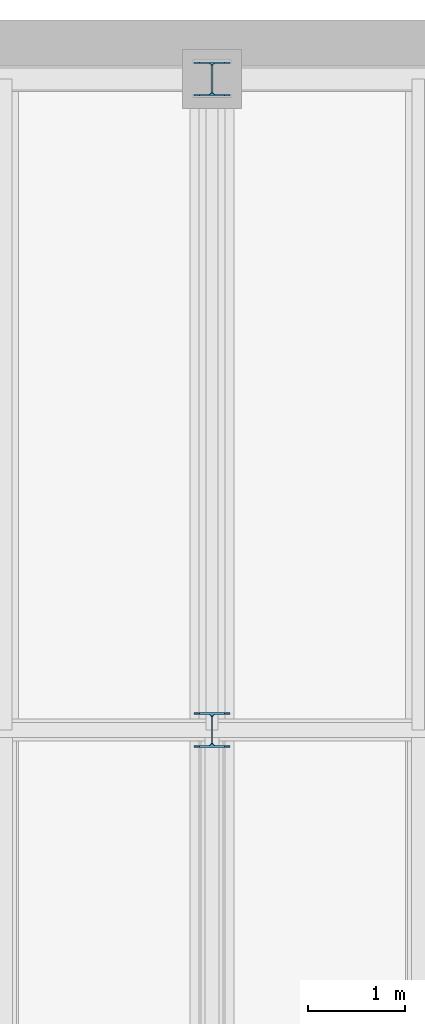
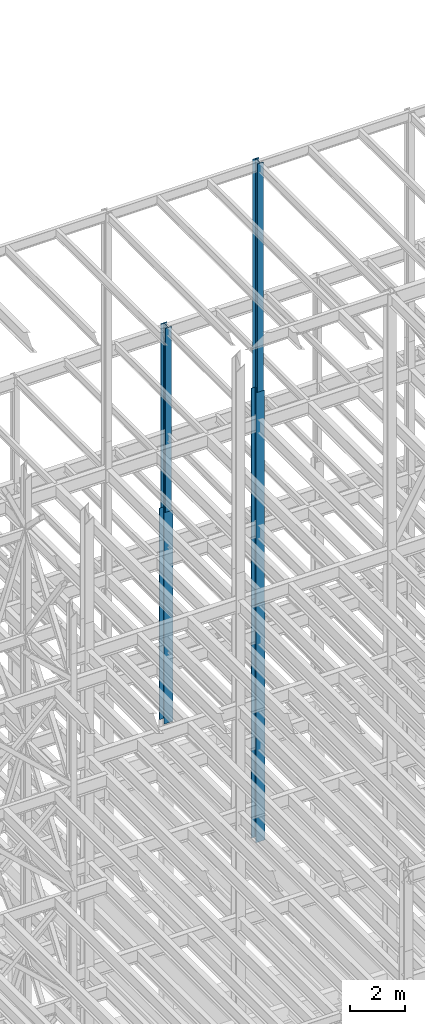
# One storey, part 60 of 150: 5 columns.
"""IFC2X3 building model written with IfcOpenShell, lengths in millimetres."""

from ifc_helpers import new_model, si_unit, frame, origin_with_axes, origin_2d_with_axis, place, context, subcontext, project, spatial, i_section, extrude, material, type_object, element, save


model = new_model("IFC2X3")

# Units and contexts
model_context = context("Model", 3, precision=1e-05, world=origin_with_axes())
body_context = subcontext(model_context, "Body", "Model", "MODEL_VIEW")
ifc_project = project(units=[si_unit("LENGTHUNIT", "METRE", prefix="MILLI"), si_unit("AREAUNIT", "SQUARE_METRE"), si_unit("VOLUMEUNIT", "CUBIC_METRE"), si_unit("MASSUNIT", "GRAM", prefix="KILO"), si_unit("TIMEUNIT", "SECOND"), si_unit("PLANEANGLEUNIT", "RADIAN"), si_unit("SOLIDANGLEUNIT", "STERADIAN"), si_unit("THERMODYNAMICTEMPERATUREUNIT", "DEGREE_CELSIUS"), si_unit("LUMINOUSINTENSITYUNIT", "LUMEN")], contexts=[model_context])

# Site, building, storey
site_placement = place(None, origin_with_axes())
site = spatial("IfcSite", under=ifc_project, at=site_placement, CompositionType="ELEMENT")
building_placement = place(site_placement, origin_with_axes())
building = spatial("IfcBuilding", under=site, at=building_placement, Name="Undefined", CompositionType="ELEMENT")
storey_placement = place(building_placement, origin_with_axes())
storey = spatial("IfcBuildingStorey", under=building, at=storey_placement, Name="Undefined", CompositionType="ELEMENT", Elevation=0.0)

# Columns
ifc_material = material(Name="STEEL/A992")
column_type_1 = type_object("IfcColumnType", Name="W14X61", PredefinedType="NOTDEFINED")
column_1_placement = place(storey_placement, frame((24587.2, 38862.0, 46253.4), z_axis=(0.0, 0.0, 1.0), x_axis=(1.0, 0.0, 0.0)))
element("IfcColumn", 1, at=column_1_placement, inside=storey, type_object=column_type_1, material=ifc_material, Name="COLUMN", ObjectType="W14X61", context=body_context, shape_type="SweptSolid", body=[
    extrude(i_section(OverallWidth=254.0, OverallDepth=352.425, WebThickness=9.5249, FlangeThickness=16.383, FilletRadius=21.717, at=origin_2d_with_axis()), frame((0.0, 0.0, 8229.60000000002), z_axis=(0.0, 0.0, -1.0), x_axis=(-1.0, 0.0, 0.0)), (0.0, 0.0, 1.0), 8229.60000000002),
])
column_type_2 = type_object("IfcColumnType", Name="W14X90", PredefinedType="NOTDEFINED")
column_2_placement = place(storey_placement, frame((24587.2, 38862.0, 36804.6012877801), z_axis=(0.0, 0.0, 1.0), x_axis=(1.0, 0.0, 0.0)))
element("IfcColumn", 2, at=column_2_placement, inside=storey, type_object=column_type_2, material=ifc_material, Name="COLUMN", ObjectType="W14X90", context=body_context, shape_type="SweptSolid", body=[
    extrude(i_section(OverallWidth=368.3, OverallDepth=355.6, WebThickness=11.1125, FlangeThickness=18.034, FilletRadius=32.7659, at=origin_2d_with_axis()), frame((0.0, 0.0, 9448.79776734), z_axis=(0.0, 0.0, -1.0), x_axis=(-1.0, 0.0, 0.0)), (0.0, 0.0, 1.0), 9448.79776734),
])
column_3_placement = place(storey_placement, frame((24587.2, 32131.0, 46253.4009448801), z_axis=(0.0, 0.0, 1.0), x_axis=(1.0, 0.0, 0.0)))
element("IfcColumn", 3, at=column_3_placement, inside=storey, type_object=column_type_2, material=ifc_material, Name="COLUMN", ObjectType="W14X90", context=body_context, shape_type="SweptSolid", body=[
    extrude(i_section(OverallWidth=368.3, OverallDepth=355.6, WebThickness=11.1125, FlangeThickness=18.034, FilletRadius=32.7659, at=origin_2d_with_axis()), frame((0.0, 0.0, 9448.79905511992), z_axis=(0.0, 0.0, -1.0), x_axis=(-1.0, 0.0, 0.0)), (0.0, 0.0, 1.0), 9448.7990551199),
])
column_type_3 = type_object("IfcColumnType", Name="W14X99", PredefinedType="NOTDEFINED")
column_4_placement = place(storey_placement, frame((24587.2, 32131.0, 35585.4), z_axis=(0.0, 0.0, 1.0), x_axis=(1.0, 0.0, 0.0)))
element("IfcColumn", 4, at=column_4_placement, inside=storey, type_object=column_type_3, material=ifc_material, Name="COLUMN", ObjectType="W14X99", context=body_context, shape_type="SweptSolid", body=[
    extrude(i_section(OverallWidth=370.84, OverallDepth=358.775, WebThickness=12.6999, FlangeThickness=19.812, FilletRadius=32.5755, at=origin_2d_with_axis()), frame((0.0, 0.0, 10668.0009448801), z_axis=(0.0, 0.0, -1.0), x_axis=(-1.0, 0.0, 0.0)), (0.0, 0.0, 1.0), 10668.0009448801),
])
column_type_4 = type_object("IfcColumnType", Name="W14X82", PredefinedType="NOTDEFINED")
column_5_placement = place(storey_placement, frame((24587.2, 32131.0, 55702.2), z_axis=(0.0, 0.0, 1.0), x_axis=(1.0, 0.0, 0.0)))
element("IfcColumn", 5, at=column_5_placement, inside=storey, type_object=column_type_4, material=ifc_material, Name="COLUMN", ObjectType="W14X82", context=body_context, shape_type="SweptSolid", body=[
    extrude(i_section(OverallWidth=256.54, OverallDepth=361.95, WebThickness=12.6999, FlangeThickness=21.717, FilletRadius=21.1455, at=origin_2d_with_axis()), frame((0.0, 0.0, 10210.8), z_axis=(0.0, 0.0, -1.0), x_axis=(-1.0, 0.0, 0.0)), (0.0, 0.0, 1.0), 10210.8),
])

save(model, "model.ifc")
